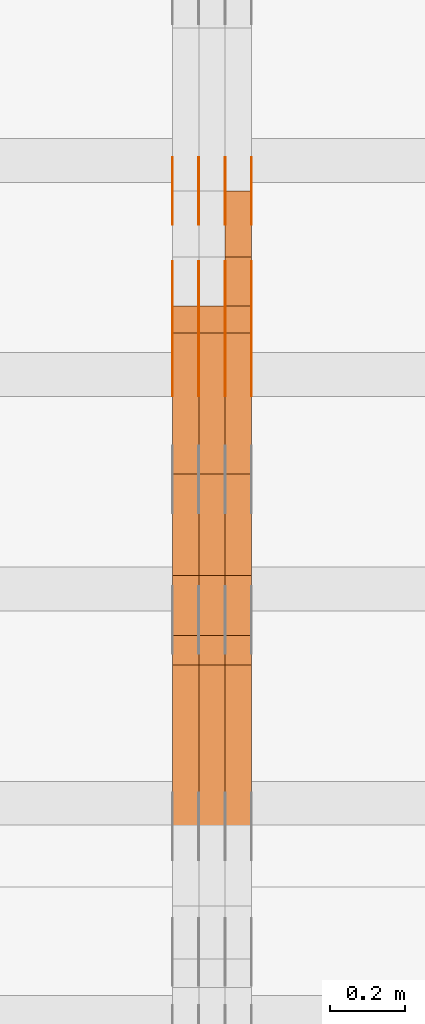
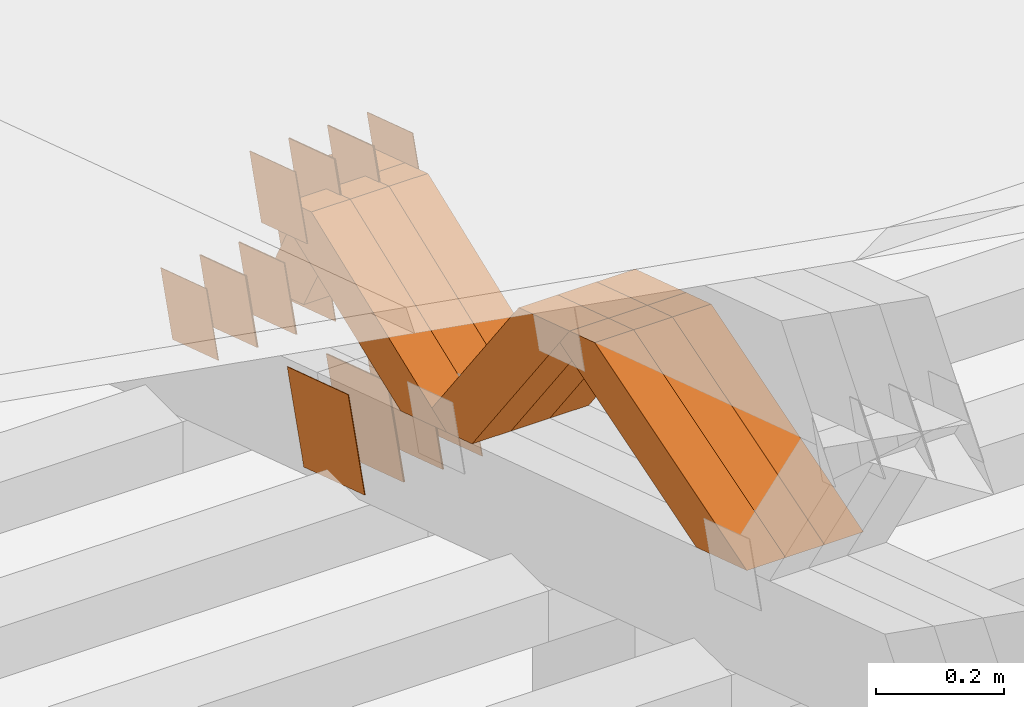
# One storey, part 198 of 385: 28 proxies.
"""IFC2X3 building model written with IfcOpenShell, lengths in millimetres."""

from ifc_helpers import new_model, entity, si_unit, converted_unit, derived_unit, direction, frame, origin, place, context, subcontext, project, spatial, polyline, outline, extrude, source, transform, mapped, material, type_object, type_shapes, element, save


model = new_model("IFC2X3")

# Units and contexts
model_context = context("Model", 3, precision=0.01, world=origin(), true_north=direction((6.12303176911189e-17, 1.0)))
body_context = subcontext(model_context, "Body", "Model", "MODEL_VIEW")
ifc_project = project(units=[si_unit("LENGTHUNIT", "METRE", prefix="MILLI"), si_unit("AREAUNIT", "SQUARE_METRE"), si_unit("VOLUMEUNIT", "CUBIC_METRE"), converted_unit("PLANEANGLEUNIT", "DEGREE", entity("IfcRatioMeasure", 0.0174532925199433), si_unit("PLANEANGLEUNIT", "RADIAN"), dimensions=[0, 0, 0, 0, 0, 0, 0]), si_unit("MASSUNIT", "GRAM", prefix="KILO"), derived_unit("MASSDENSITYUNIT", [(si_unit("MASSUNIT", "GRAM", prefix="KILO"), 1), (si_unit("LENGTHUNIT", "METRE"), -3)]), si_unit("TIMEUNIT", "SECOND"), si_unit("FREQUENCYUNIT", "HERTZ"), si_unit("THERMODYNAMICTEMPERATUREUNIT", "DEGREE_CELSIUS"), derived_unit("THERMALTRANSMITTANCEUNIT", [(si_unit("MASSUNIT", "GRAM", prefix="KILO"), 1), (si_unit("THERMODYNAMICTEMPERATUREUNIT", "KELVIN"), -1), (si_unit("TIMEUNIT", "SECOND"), -3)]), derived_unit("VOLUMETRICFLOWRATEUNIT", [(si_unit("LENGTHUNIT", "METRE"), 3), (si_unit("TIMEUNIT", "SECOND"), -1)]), si_unit("ELECTRICCURRENTUNIT", "AMPERE"), si_unit("ELECTRICVOLTAGEUNIT", "VOLT"), si_unit("POWERUNIT", "WATT"), si_unit("FORCEUNIT", "NEWTON", prefix="KILO"), si_unit("ILLUMINANCEUNIT", "LUX"), si_unit("LUMINOUSFLUXUNIT", "LUMEN"), si_unit("LUMINOUSINTENSITYUNIT", "CANDELA"), derived_unit("USERDEFINED", [(si_unit("MASSUNIT", "GRAM", prefix="KILO"), -1), (si_unit("LENGTHUNIT", "METRE"), -2), (si_unit("TIMEUNIT", "SECOND"), 3), (si_unit("LUMINOUSFLUXUNIT", "LUMEN"), 1)]), derived_unit("LINEARVELOCITYUNIT", [(si_unit("LENGTHUNIT", "METRE"), 1), (si_unit("TIMEUNIT", "SECOND"), -1)]), si_unit("PRESSUREUNIT", "PASCAL"), derived_unit("USERDEFINED", [(si_unit("LENGTHUNIT", "METRE"), -2), (si_unit("MASSUNIT", "GRAM", prefix="KILO"), 1), (si_unit("TIMEUNIT", "SECOND"), -2)])], contexts=[model_context])

# Site, building, storey
site_placement = place(None, origin())
site = spatial("IfcSite", under=ifc_project, at=site_placement, CompositionType="ELEMENT")
building_placement = place(site_placement, origin())
building = spatial("IfcBuilding", under=site, at=building_placement, CompositionType="ELEMENT")
storey_placement = place(building_placement, origin())
storey = spatial("IfcBuildingStorey", under=building, at=storey_placement, Name="Default", CompositionType="ELEMENT", Elevation=0.0)

# Proxies
ifc_material_1 = material(Name="IfcSurfaceStyle #171972")
building_element_proxy_type_1 = type_object("IfcBuildingElementProxyType", PredefinedType="NOTDEFINED", material=ifc_material_1)
shared_shape_1 = source(origin(), body_context, "Body", "SweptSolid", [
    extrude(outline(polyline([(-74.9998794200123, -59.999984515643), (74.9998565677174, -59.999984515643), (74.9998794200123, 59.999984515643), (-74.9998565677174, 59.999984515643), (-74.9998794200123, -59.999984515643)])), frame((75.0000769557496, 60.0000596852268, 0.0), z_axis=(0.0, 0.0, 1.0), x_axis=(-1.0, 0.0, 0.0)), (0.0, 0.0, 1.0), 1.3),
])
type_shapes(building_element_proxy_type_1, [shared_shape_1])
proxy_1_placement = place(building_placement, frame((12386.3, 22649.3668870864, 1282.62115477841), z_axis=(-1.0, 0.0, 0.0), x_axis=(0.0, -0.951056516295124, 0.309016994375039)))
element("IfcBuildingElementProxy", 1, at=proxy_1_placement, inside=storey, type_object=building_element_proxy_type_1, material=ifc_material_1, context=body_context, shape_type="MappedRepresentation", body=[
    mapped(shared_shape_1, transform((0.0, 0.0, 0.0), scale=1.0)),
])
ifc_material_2 = material(Name="IfcSurfaceStyle #171915")
building_element_proxy_type_2 = type_object("IfcBuildingElementProxyType", PredefinedType="NOTDEFINED", material=ifc_material_2)
shared_shape_2 = source(origin(), body_context, "Body", "SweptSolid", [
    extrude(outline(polyline([(-74.9998794200123, -59.999984515643), (74.9998565677174, -59.999984515643), (74.9998794200123, 59.999984515643), (-74.9998565677174, 59.999984515643), (-74.9998794200123, -59.999984515643)])), frame((75.0000769557496, 60.0000596852268, 0.0), z_axis=(0.0, 0.0, 1.0), x_axis=(-1.0, 0.0, 0.0)), (0.0, 0.0, 1.0), 1.3),
])
type_shapes(building_element_proxy_type_2, [shared_shape_2])
proxy_2_placement = place(building_placement, frame((12315.0, 22649.3668870864, 1282.62115477841), z_axis=(-1.0, 0.0, 0.0), x_axis=(0.0, -0.951056516295124, 0.309016994375039)))
element("IfcBuildingElementProxy", 2, at=proxy_2_placement, inside=storey, type_object=building_element_proxy_type_2, material=ifc_material_2, context=body_context, shape_type="MappedRepresentation", body=[
    mapped(shared_shape_2, transform((0.0, 0.0, 0.0), scale=1.0)),
])
ifc_material_3 = material(Name="IfcSurfaceStyle #171858")
building_element_proxy_type_3 = type_object("IfcBuildingElementProxyType", PredefinedType="NOTDEFINED", material=ifc_material_3)
shared_shape_3 = source(origin(), body_context, "Body", "SweptSolid", [
    extrude(outline(polyline([(-74.9998794200123, -59.999984515643), (74.9998565677174, -59.999984515643), (74.9998794200123, 59.999984515643), (-74.9998565677174, 59.999984515643), (-74.9998794200123, -59.999984515643)])), frame((75.0000769557496, 60.0000596852268, 0.0), z_axis=(0.0, 0.0, 1.0), x_axis=(-1.0, 0.0, 0.0)), (0.0, 0.0, 1.0), 1.3),
])
type_shapes(building_element_proxy_type_3, [shared_shape_3])
proxy_3_placement = place(building_placement, frame((12316.3, 22649.3668870864, 1282.62115477841), z_axis=(-1.0, 0.0, 0.0), x_axis=(0.0, -0.951056516295124, 0.309016994375039)))
element("IfcBuildingElementProxy", 3, at=proxy_3_placement, inside=storey, type_object=building_element_proxy_type_3, material=ifc_material_3, context=body_context, shape_type="MappedRepresentation", body=[
    mapped(shared_shape_3, transform((0.0, 0.0, 0.0), scale=1.0)),
])
ifc_material_4 = material(Name="IfcSurfaceStyle #171801")
building_element_proxy_type_4 = type_object("IfcBuildingElementProxyType", PredefinedType="NOTDEFINED", material=ifc_material_4)
shared_shape_4 = source(origin(), body_context, "Body", "SweptSolid", [
    extrude(outline(polyline([(-74.9998794200123, -59.999984515643), (74.9998565677174, -59.999984515643), (74.9998794200123, 59.999984515643), (-74.9998565677174, 59.999984515643), (-74.9998794200123, -59.999984515643)])), frame((75.0000769557496, 60.0000596852268, 0.0), z_axis=(0.0, 0.0, 1.0), x_axis=(-1.0, 0.0, 0.0)), (0.0, 0.0, 1.0), 1.29999999999999),
])
type_shapes(building_element_proxy_type_4, [shared_shape_4])
proxy_4_placement = place(building_placement, frame((12245.0, 22649.3668870864, 1282.62115477841), z_axis=(-1.0, 0.0, 0.0), x_axis=(0.0, -0.951056516295124, 0.309016994375039)))
element("IfcBuildingElementProxy", 4, at=proxy_4_placement, inside=storey, type_object=building_element_proxy_type_4, material=ifc_material_4, context=body_context, shape_type="MappedRepresentation", body=[
    mapped(shared_shape_4, transform((0.0, 0.0, 0.0), scale=1.0)),
])
ifc_material_5 = material(Name="IfcSurfaceStyle #171744")
building_element_proxy_type_5 = type_object("IfcBuildingElementProxyType", PredefinedType="NOTDEFINED", material=ifc_material_5)
shared_shape_5 = source(origin(), body_context, "Body", "SweptSolid", [
    extrude(outline(polyline([(-74.9998794200123, -59.999984515643), (74.9998565677174, -59.999984515643), (74.9998794200123, 59.999984515643), (-74.9998565677174, 59.999984515643), (-74.9998794200123, -59.999984515643)])), frame((75.0000769557496, 60.0000596852268, 0.0), z_axis=(0.0, 0.0, 1.0), x_axis=(-1.0, 0.0, 0.0)), (0.0, 0.0, 1.0), 1.29999999999999),
])
type_shapes(building_element_proxy_type_5, [shared_shape_5])
proxy_5_placement = place(building_placement, frame((12246.3, 22649.3668870864, 1282.62115477841), z_axis=(-1.0, 0.0, 0.0), x_axis=(0.0, -0.951056516295124, 0.309016994375039)))
element("IfcBuildingElementProxy", 5, at=proxy_5_placement, inside=storey, type_object=building_element_proxy_type_5, material=ifc_material_5, context=body_context, shape_type="MappedRepresentation", body=[
    mapped(shared_shape_5, transform((0.0, 0.0, 0.0), scale=1.0)),
])
ifc_material_6 = material(Name="IfcSurfaceStyle #171687")
building_element_proxy_type_6 = type_object("IfcBuildingElementProxyType", PredefinedType="NOTDEFINED", material=ifc_material_6)
shared_shape_6 = source(origin(), body_context, "Body", "SweptSolid", [
    extrude(outline(polyline([(-74.9998794200123, -59.999984515643), (74.9998565677174, -59.999984515643), (74.9998794200123, 59.999984515643), (-74.9998565677174, 59.999984515643), (-74.9998794200123, -59.999984515643)])), frame((75.0000769557496, 60.0000596852268, 0.0), z_axis=(0.0, 0.0, 1.0), x_axis=(-1.0, 0.0, 0.0)), (0.0, 0.0, 1.0), 1.29999999999999),
])
type_shapes(building_element_proxy_type_6, [shared_shape_6])
proxy_6_placement = place(building_placement, frame((12175.0, 22649.3668870864, 1282.62115477841), z_axis=(-1.0, 0.0, 0.0), x_axis=(0.0, -0.951056516295124, 0.309016994375039)))
element("IfcBuildingElementProxy", 6, at=proxy_6_placement, inside=storey, type_object=building_element_proxy_type_6, material=ifc_material_6, context=body_context, shape_type="MappedRepresentation", body=[
    mapped(shared_shape_6, transform((0.0, 0.0, 0.0), scale=1.0)),
])
ifc_material_7 = material(Name="IfcSurfaceStyle #171288")
building_element_proxy_type_7 = type_object("IfcBuildingElementProxyType", PredefinedType="NOTDEFINED", material=ifc_material_7)
shared_shape_7 = source(origin(), body_context, "Body", "SweptSolid", [
    extrude(outline(polyline([(-99.9999579276585, -84.0000593595837), (100.000141865112, -84.0000593595837), (99.9999579276589, 84.0000593595837), (-100.000141865112, 84.0000593595837), (-99.9999579276585, -84.0000593595837)])), frame((100.000141865112, 84.0000593595837, 0.0), z_axis=(0.0, 0.0, 1.0), x_axis=(-1.0, 0.0, 0.0)), (0.0, 0.0, 1.0), 1.3),
])
type_shapes(building_element_proxy_type_7, [shared_shape_7])
proxy_7_placement = place(building_placement, frame((12386.3, 22239.7296395088, 1287.96775368191), z_axis=(-1.0, 0.0, 0.0), x_axis=(0.0, -0.951056516295124, 0.309016994375039)))
element("IfcBuildingElementProxy", 7, at=proxy_7_placement, inside=storey, type_object=building_element_proxy_type_7, material=ifc_material_7, context=body_context, shape_type="MappedRepresentation", body=[
    mapped(shared_shape_7, transform((0.0, 0.0, 0.0), scale=1.0)),
])
ifc_material_8 = material(Name="IfcSurfaceStyle #171231")
building_element_proxy_type_8 = type_object("IfcBuildingElementProxyType", PredefinedType="NOTDEFINED", material=ifc_material_8)
shared_shape_8 = source(origin(), body_context, "Body", "SweptSolid", [
    extrude(outline(polyline([(-99.9999579276585, -84.0000593595837), (100.000141865112, -84.0000593595837), (99.9999579276589, 84.0000593595837), (-100.000141865112, 84.0000593595837), (-99.9999579276585, -84.0000593595837)])), frame((100.000141865112, 84.0000593595837, 0.0), z_axis=(0.0, 0.0, 1.0), x_axis=(-1.0, 0.0, 0.0)), (0.0, 0.0, 1.0), 1.3),
])
type_shapes(building_element_proxy_type_8, [shared_shape_8])
proxy_8_placement = place(building_placement, frame((12315.0, 22239.7296395088, 1287.96775368191), z_axis=(-1.0, 0.0, 0.0), x_axis=(0.0, -0.951056516295124, 0.309016994375039)))
element("IfcBuildingElementProxy", 8, at=proxy_8_placement, inside=storey, type_object=building_element_proxy_type_8, material=ifc_material_8, context=body_context, shape_type="MappedRepresentation", body=[
    mapped(shared_shape_8, transform((0.0, 0.0, 0.0), scale=1.0)),
])
ifc_material_9 = material(Name="IfcSurfaceStyle #171174")
building_element_proxy_type_9 = type_object("IfcBuildingElementProxyType", PredefinedType="NOTDEFINED", material=ifc_material_9)
shared_shape_9 = source(origin(), body_context, "Body", "SweptSolid", [
    extrude(outline(polyline([(-99.9999579276585, -84.0000593595837), (100.000141865112, -84.0000593595837), (99.9999579276589, 84.0000593595837), (-100.000141865112, 84.0000593595837), (-99.9999579276585, -84.0000593595837)])), frame((100.000141865112, 84.0000593595837, 0.0), z_axis=(0.0, 0.0, 1.0), x_axis=(-1.0, 0.0, 0.0)), (0.0, 0.0, 1.0), 1.3),
])
type_shapes(building_element_proxy_type_9, [shared_shape_9])
proxy_9_placement = place(building_placement, frame((12316.3, 22239.7296395088, 1287.96775368191), z_axis=(-1.0, 0.0, 0.0), x_axis=(0.0, -0.951056516295124, 0.309016994375039)))
element("IfcBuildingElementProxy", 9, at=proxy_9_placement, inside=storey, type_object=building_element_proxy_type_9, material=ifc_material_9, context=body_context, shape_type="MappedRepresentation", body=[
    mapped(shared_shape_9, transform((0.0, 0.0, 0.0), scale=1.0)),
])
ifc_material_10 = material(Name="IfcSurfaceStyle #171117")
building_element_proxy_type_10 = type_object("IfcBuildingElementProxyType", PredefinedType="NOTDEFINED", material=ifc_material_10)
shared_shape_10 = source(origin(), body_context, "Body", "SweptSolid", [
    extrude(outline(polyline([(-99.9999579276585, -84.0000593595837), (100.000141865112, -84.0000593595837), (99.9999579276589, 84.0000593595837), (-100.000141865112, 84.0000593595837), (-99.9999579276585, -84.0000593595837)])), frame((100.000141865112, 84.0000593595837, 0.0), z_axis=(0.0, 0.0, 1.0), x_axis=(-1.0, 0.0, 0.0)), (0.0, 0.0, 1.0), 1.29999999999998),
])
type_shapes(building_element_proxy_type_10, [shared_shape_10])
proxy_10_placement = place(building_placement, frame((12245.0, 22239.7296395088, 1287.96775368191), z_axis=(-1.0, 0.0, 0.0), x_axis=(0.0, -0.951056516295124, 0.309016994375039)))
element("IfcBuildingElementProxy", 10, at=proxy_10_placement, inside=storey, type_object=building_element_proxy_type_10, material=ifc_material_10, context=body_context, shape_type="MappedRepresentation", body=[
    mapped(shared_shape_10, transform((0.0, 0.0, 0.0), scale=1.0)),
])
ifc_material_11 = material(Name="IfcSurfaceStyle #171060")
building_element_proxy_type_11 = type_object("IfcBuildingElementProxyType", PredefinedType="NOTDEFINED", material=ifc_material_11)
shared_shape_11 = source(origin(), body_context, "Body", "SweptSolid", [
    extrude(outline(polyline([(-99.9999579276585, -84.0000593595837), (100.000141865112, -84.0000593595837), (99.9999579276589, 84.0000593595837), (-100.000141865112, 84.0000593595837), (-99.9999579276585, -84.0000593595837)])), frame((100.000141865112, 84.0000593595837, 0.0), z_axis=(0.0, 0.0, 1.0), x_axis=(-1.0, 0.0, 0.0)), (0.0, 0.0, 1.0), 1.29999999999998),
])
type_shapes(building_element_proxy_type_11, [shared_shape_11])
proxy_11_placement = place(building_placement, frame((12246.3, 22239.7296395088, 1287.96775368191), z_axis=(-1.0, 0.0, 0.0), x_axis=(0.0, -0.951056516295124, 0.309016994375039)))
element("IfcBuildingElementProxy", 11, at=proxy_11_placement, inside=storey, type_object=building_element_proxy_type_11, material=ifc_material_11, context=body_context, shape_type="MappedRepresentation", body=[
    mapped(shared_shape_11, transform((0.0, 0.0, 0.0), scale=1.0)),
])
ifc_material_12 = material(Name="IfcSurfaceStyle #171003")
building_element_proxy_type_12 = type_object("IfcBuildingElementProxyType", PredefinedType="NOTDEFINED", material=ifc_material_12)
shared_shape_12 = source(origin(), body_context, "Body", "SweptSolid", [
    extrude(outline(polyline([(-99.9999579276585, -84.0000593595837), (100.000141865112, -84.0000593595837), (99.9999579276589, 84.0000593595837), (-100.000141865112, 84.0000593595837), (-99.9999579276585, -84.0000593595837)])), frame((100.000141865112, 84.0000593595837, 0.0), z_axis=(0.0, 0.0, 1.0), x_axis=(-1.0, 0.0, 0.0)), (0.0, 0.0, 1.0), 1.29999999999999),
])
type_shapes(building_element_proxy_type_12, [shared_shape_12])
proxy_12_placement = place(building_placement, frame((12175.0, 22239.7296395088, 1287.96775368191), z_axis=(-1.0, 0.0, 0.0), x_axis=(0.0, -0.951056516295124, 0.309016994375039)))
element("IfcBuildingElementProxy", 12, at=proxy_12_placement, inside=storey, type_object=building_element_proxy_type_12, material=ifc_material_12, context=body_context, shape_type="MappedRepresentation", body=[
    mapped(shared_shape_12, transform((0.0, 0.0, 0.0), scale=1.0)),
])
ifc_material_13 = material(Name="IfcSurfaceStyle #162738")
building_element_proxy_type_13 = type_object("IfcBuildingElementProxyType", PredefinedType="NOTDEFINED", material=ifc_material_13)
shared_shape_13 = source(origin(), body_context, "Body", "SweptSolid", [
    extrude(outline(polyline([(-74.9998794200069, -59.9999845156358), (74.9998565677229, -59.9999845156358), (74.9998794200069, 59.9999845156358), (-74.9998565677229, 59.9999845156358), (-74.9998794200069, -59.9999845156358)])), frame((75.0000966453795, 60.0000596852335, 0.0), z_axis=(0.0, 0.0, 1.0), x_axis=(-1.0, 0.0, 0.0)), (0.0, 0.0, 1.0), 1.3),
])
type_shapes(building_element_proxy_type_13, [shared_shape_13])
proxy_13_placement = place(building_placement, frame((12386.3, 22372.1881948749, 1673.08440552992), z_axis=(-1.0, 0.0, 0.0), x_axis=(0.0, -0.951056516295154, 0.309016994374948)))
element("IfcBuildingElementProxy", 13, at=proxy_13_placement, inside=storey, type_object=building_element_proxy_type_13, material=ifc_material_13, context=body_context, shape_type="MappedRepresentation", body=[
    mapped(shared_shape_13, transform((0.0, 0.0, 0.0), scale=1.0)),
])
ifc_material_14 = material(Name="IfcSurfaceStyle #162681")
building_element_proxy_type_14 = type_object("IfcBuildingElementProxyType", PredefinedType="NOTDEFINED", material=ifc_material_14)
shared_shape_14 = source(origin(), body_context, "Body", "SweptSolid", [
    extrude(outline(polyline([(-74.9998794200069, -59.9999845156358), (74.9998565677229, -59.9999845156358), (74.9998794200069, 59.9999845156358), (-74.9998565677229, 59.9999845156358), (-74.9998794200069, -59.9999845156358)])), frame((75.0000966453795, 60.0000596852335, 0.0), z_axis=(0.0, 0.0, 1.0), x_axis=(-1.0, 0.0, 0.0)), (0.0, 0.0, 1.0), 1.3),
])
type_shapes(building_element_proxy_type_14, [shared_shape_14])
proxy_14_placement = place(building_placement, frame((12315.0, 22372.1881948749, 1673.08440552992), z_axis=(-1.0, 0.0, 0.0), x_axis=(0.0, -0.951056516295154, 0.309016994374948)))
element("IfcBuildingElementProxy", 14, at=proxy_14_placement, inside=storey, type_object=building_element_proxy_type_14, material=ifc_material_14, context=body_context, shape_type="MappedRepresentation", body=[
    mapped(shared_shape_14, transform((0.0, 0.0, 0.0), scale=1.0)),
])
ifc_material_15 = material(Name="IfcSurfaceStyle #162624")
building_element_proxy_type_15 = type_object("IfcBuildingElementProxyType", PredefinedType="NOTDEFINED", material=ifc_material_15)
shared_shape_15 = source(origin(), body_context, "Body", "SweptSolid", [
    extrude(outline(polyline([(-74.9998794200069, -59.9999845156358), (74.9998565677229, -59.9999845156358), (74.9998794200069, 59.9999845156358), (-74.9998565677229, 59.9999845156358), (-74.9998794200069, -59.9999845156358)])), frame((75.0000966453795, 60.0000596852335, 0.0), z_axis=(0.0, 0.0, 1.0), x_axis=(-1.0, 0.0, 0.0)), (0.0, 0.0, 1.0), 1.3),
])
type_shapes(building_element_proxy_type_15, [shared_shape_15])
proxy_15_placement = place(building_placement, frame((12316.3, 22372.1881948749, 1673.08440552992), z_axis=(-1.0, 0.0, 0.0), x_axis=(0.0, -0.951056516295154, 0.309016994374948)))
element("IfcBuildingElementProxy", 15, at=proxy_15_placement, inside=storey, type_object=building_element_proxy_type_15, material=ifc_material_15, context=body_context, shape_type="MappedRepresentation", body=[
    mapped(shared_shape_15, transform((0.0, 0.0, 0.0), scale=1.0)),
])
ifc_material_16 = material(Name="IfcSurfaceStyle #162567")
building_element_proxy_type_16 = type_object("IfcBuildingElementProxyType", PredefinedType="NOTDEFINED", material=ifc_material_16)
shared_shape_16 = source(origin(), body_context, "Body", "SweptSolid", [
    extrude(outline(polyline([(-74.9998794200069, -59.9999845156358), (74.9998565677229, -59.9999845156358), (74.9998794200069, 59.9999845156358), (-74.9998565677229, 59.9999845156358), (-74.9998794200069, -59.9999845156358)])), frame((75.0000966453795, 60.0000596852335, 0.0), z_axis=(0.0, 0.0, 1.0), x_axis=(-1.0, 0.0, 0.0)), (0.0, 0.0, 1.0), 1.29999999999999),
])
type_shapes(building_element_proxy_type_16, [shared_shape_16])
proxy_16_placement = place(building_placement, frame((12245.0, 22372.1881948749, 1673.08440552992), z_axis=(-1.0, 0.0, 0.0), x_axis=(0.0, -0.951056516295154, 0.309016994374948)))
element("IfcBuildingElementProxy", 16, at=proxy_16_placement, inside=storey, type_object=building_element_proxy_type_16, material=ifc_material_16, context=body_context, shape_type="MappedRepresentation", body=[
    mapped(shared_shape_16, transform((0.0, 0.0, 0.0), scale=1.0)),
])
ifc_material_17 = material(Name="IfcSurfaceStyle #162510")
building_element_proxy_type_17 = type_object("IfcBuildingElementProxyType", PredefinedType="NOTDEFINED", material=ifc_material_17)
shared_shape_17 = source(origin(), body_context, "Body", "SweptSolid", [
    extrude(outline(polyline([(-74.9998794200069, -59.9999845156358), (74.9998565677229, -59.9999845156358), (74.9998794200069, 59.9999845156358), (-74.9998565677229, 59.9999845156358), (-74.9998794200069, -59.9999845156358)])), frame((75.0000966453795, 60.0000596852335, 0.0), z_axis=(0.0, 0.0, 1.0), x_axis=(-1.0, 0.0, 0.0)), (0.0, 0.0, 1.0), 1.29999999999999),
])
type_shapes(building_element_proxy_type_17, [shared_shape_17])
proxy_17_placement = place(building_placement, frame((12246.3, 22372.1881948749, 1673.08440552992), z_axis=(-1.0, 0.0, 0.0), x_axis=(0.0, -0.951056516295154, 0.309016994374948)))
element("IfcBuildingElementProxy", 17, at=proxy_17_placement, inside=storey, type_object=building_element_proxy_type_17, material=ifc_material_17, context=body_context, shape_type="MappedRepresentation", body=[
    mapped(shared_shape_17, transform((0.0, 0.0, 0.0), scale=1.0)),
])
ifc_material_18 = material(Name="IfcSurfaceStyle #162453")
building_element_proxy_type_18 = type_object("IfcBuildingElementProxyType", PredefinedType="NOTDEFINED", material=ifc_material_18)
shared_shape_18 = source(origin(), body_context, "Body", "SweptSolid", [
    extrude(outline(polyline([(-74.9998794200069, -59.9999845156358), (74.9998565677229, -59.9999845156358), (74.9998794200069, 59.9999845156358), (-74.9998565677229, 59.9999845156358), (-74.9998794200069, -59.9999845156358)])), frame((75.0000966453795, 60.0000596852335, 0.0), z_axis=(0.0, 0.0, 1.0), x_axis=(-1.0, 0.0, 0.0)), (0.0, 0.0, 1.0), 1.29999999999999),
])
type_shapes(building_element_proxy_type_18, [shared_shape_18])
proxy_18_placement = place(building_placement, frame((12175.0, 22372.1881948749, 1673.08440552992), z_axis=(-1.0, 0.0, 0.0), x_axis=(0.0, -0.951056516295154, 0.309016994374948)))
element("IfcBuildingElementProxy", 18, at=proxy_18_placement, inside=storey, type_object=building_element_proxy_type_18, material=ifc_material_18, context=body_context, shape_type="MappedRepresentation", body=[
    mapped(shared_shape_18, transform((0.0, 0.0, 0.0), scale=1.0)),
])
ifc_material_19 = material(Name="IfcSurfaceStyle #151182")
building_element_proxy_type_19 = type_object("IfcBuildingElementProxyType", Name="T1-W20 151180", PredefinedType="NOTDEFINED", material=ifc_material_19)
shared_shape_19 = source(origin(), body_context, "Body", "SweptSolid", [
    extrude(outline(polyline([(-355.264945969921, -47.5000317999193), (141.064821099313, -47.5000317999193), (208.541978467889, 8.19311626391928e-05), (225.96877763549, 47.499990834338), (-220.31063123277, 47.4999908343379), (-355.264945969921, -47.5000317999193)])), frame((225.968921063481, 47.5000683592689, 0.0), z_axis=(0.0, 0.0, 1.0), x_axis=(-1.0, 0.0, 0.0)), (0.0, 0.0, 1.0), 70.0),
])
type_shapes(building_element_proxy_type_19, [shared_shape_19])
proxy_19_placement = place(building_placement, frame((12385.0, 21443.7472302196, 2007.54830804072), z_axis=(-1.0, 0.0, 0.0), x_axis=(0.0, -0.95556995517236, -0.29476441571515)))
element("IfcBuildingElementProxy", 19, at=proxy_19_placement, inside=storey, type_object=building_element_proxy_type_19, material=ifc_material_19, Name="T1-W20", context=body_context, shape_type="MappedRepresentation", body=[
    mapped(shared_shape_19, transform((0.0, 0.0, 0.0), scale=1.0)),
])
ifc_material_20 = material(Name="IfcSurfaceStyle #151116")
building_element_proxy_type_20 = type_object("IfcBuildingElementProxyType", Name="T1-W20 151114", PredefinedType="NOTDEFINED", material=ifc_material_20)
shared_shape_20 = source(origin(), body_context, "Body", "SweptSolid", [
    extrude(outline(polyline([(-355.264945969921, -47.5000317999193), (141.064821099313, -47.5000317999193), (208.541978467889, 8.19311626391928e-05), (225.96877763549, 47.499990834338), (-220.31063123277, 47.4999908343379), (-355.264945969921, -47.5000317999193)])), frame((225.968921063481, 47.5000683592689, 0.0), z_axis=(0.0, 0.0, 1.0), x_axis=(-1.0, 0.0, 0.0)), (0.0, 0.0, 1.0), 70.0),
])
type_shapes(building_element_proxy_type_20, [shared_shape_20])
proxy_20_placement = place(building_placement, frame((12315.0, 21443.7472302196, 2007.54830804072), z_axis=(-1.0, 0.0, 0.0), x_axis=(0.0, -0.95556995517236, -0.29476441571515)))
element("IfcBuildingElementProxy", 20, at=proxy_20_placement, inside=storey, type_object=building_element_proxy_type_20, material=ifc_material_20, Name="T1-W20", context=body_context, shape_type="MappedRepresentation", body=[
    mapped(shared_shape_20, transform((0.0, 0.0, 0.0), scale=1.0)),
])
ifc_material_21 = material(Name="IfcSurfaceStyle #151050")
building_element_proxy_type_21 = type_object("IfcBuildingElementProxyType", Name="T1-W20 151048", PredefinedType="NOTDEFINED", material=ifc_material_21)
shared_shape_21 = source(origin(), body_context, "Body", "SweptSolid", [
    extrude(outline(polyline([(-355.264945969921, -47.5000317999193), (141.064821099313, -47.5000317999193), (208.541978467889, 8.19311626391928e-05), (225.96877763549, 47.499990834338), (-220.31063123277, 47.4999908343379), (-355.264945969921, -47.5000317999193)])), frame((225.968921063481, 47.5000683592689, 0.0), z_axis=(0.0, 0.0, 1.0), x_axis=(-1.0, 0.0, 0.0)), (0.0, 0.0, 1.0), 70.0),
])
type_shapes(building_element_proxy_type_21, [shared_shape_21])
proxy_21_placement = place(building_placement, frame((12245.0, 21443.7472302196, 2007.54830804072), z_axis=(-1.0, 0.0, 0.0), x_axis=(0.0, -0.95556995517236, -0.29476441571515)))
element("IfcBuildingElementProxy", 21, at=proxy_21_placement, inside=storey, type_object=building_element_proxy_type_21, material=ifc_material_21, Name="T1-W20", context=body_context, shape_type="MappedRepresentation", body=[
    mapped(shared_shape_21, transform((0.0, 0.0, 0.0), scale=1.0)),
])
ifc_material_22 = material(Name="IfcSurfaceStyle #150786")
building_element_proxy_type_22 = type_object("IfcBuildingElementProxyType", Name="T1-W18 150784", PredefinedType="NOTDEFINED", material=ifc_material_22)
shared_shape_22 = source(origin(), body_context, "Body", "SweptSolid", [
    extrude(outline(polyline([(-221.504996322134, -47.4999929258616), (225.406467948779, -47.4999929258616), (211.663832468686, -0.000107703153482008), (143.08905281687, 47.5000467774384), (-358.6543569122, 47.5000467774384), (-221.504996322134, -47.4999929258616)])), frame((225.406576158364, 47.5000467774384, 0.0), z_axis=(0.0, 0.0, 1.0), x_axis=(-1.0, 0.0, 0.0)), (0.0, 0.0, 1.0), 70.0),
])
type_shapes(building_element_proxy_type_22, [shared_shape_22])
proxy_22_placement = place(building_placement, frame((12385.0, 21766.9513837803, 1583.13813361817), z_axis=(-1.0, 0.0, 0.0), x_axis=(0.0, -0.605858491298265, 0.795572428206126)))
element("IfcBuildingElementProxy", 22, at=proxy_22_placement, inside=storey, type_object=building_element_proxy_type_22, material=ifc_material_22, Name="T1-W18", context=body_context, shape_type="MappedRepresentation", body=[
    mapped(shared_shape_22, transform((0.0, 0.0, 0.0), scale=1.0)),
])
ifc_material_23 = material(Name="IfcSurfaceStyle #150720")
building_element_proxy_type_23 = type_object("IfcBuildingElementProxyType", Name="T1-W18 150718", PredefinedType="NOTDEFINED", material=ifc_material_23)
shared_shape_23 = source(origin(), body_context, "Body", "SweptSolid", [
    extrude(outline(polyline([(-221.504996322134, -47.4999929258616), (225.406467948779, -47.4999929258616), (211.663832468686, -0.000107703153482008), (143.08905281687, 47.5000467774384), (-358.6543569122, 47.5000467774384), (-221.504996322134, -47.4999929258616)])), frame((225.406576158364, 47.5000467774384, 0.0), z_axis=(0.0, 0.0, 1.0), x_axis=(-1.0, 0.0, 0.0)), (0.0, 0.0, 1.0), 70.0),
])
type_shapes(building_element_proxy_type_23, [shared_shape_23])
proxy_23_placement = place(building_placement, frame((12315.0, 21766.9513837803, 1583.13813361817), z_axis=(-1.0, 0.0, 0.0), x_axis=(0.0, -0.605858491298265, 0.795572428206126)))
element("IfcBuildingElementProxy", 23, at=proxy_23_placement, inside=storey, type_object=building_element_proxy_type_23, material=ifc_material_23, Name="T1-W18", context=body_context, shape_type="MappedRepresentation", body=[
    mapped(shared_shape_23, transform((0.0, 0.0, 0.0), scale=1.0)),
])
ifc_material_24 = material(Name="IfcSurfaceStyle #150654")
building_element_proxy_type_24 = type_object("IfcBuildingElementProxyType", Name="T1-W18 150652", PredefinedType="NOTDEFINED", material=ifc_material_24)
shared_shape_24 = source(origin(), body_context, "Body", "SweptSolid", [
    extrude(outline(polyline([(-221.504996322134, -47.4999929258616), (225.406467948779, -47.4999929258616), (211.663832468686, -0.000107703153482008), (143.08905281687, 47.5000467774384), (-358.6543569122, 47.5000467774384), (-221.504996322134, -47.4999929258616)])), frame((225.406576158364, 47.5000467774384, 0.0), z_axis=(0.0, 0.0, 1.0), x_axis=(-1.0, 0.0, 0.0)), (0.0, 0.0, 1.0), 70.0),
])
type_shapes(building_element_proxy_type_24, [shared_shape_24])
proxy_24_placement = place(building_placement, frame((12245.0, 21766.9513837803, 1583.13813361817), z_axis=(-1.0, 0.0, 0.0), x_axis=(0.0, -0.605858491298265, 0.795572428206126)))
element("IfcBuildingElementProxy", 24, at=proxy_24_placement, inside=storey, type_object=building_element_proxy_type_24, material=ifc_material_24, Name="T1-W18", context=body_context, shape_type="MappedRepresentation", body=[
    mapped(shared_shape_24, transform((0.0, 0.0, 0.0), scale=1.0)),
])
ifc_material_25 = material(Name="IfcSurfaceStyle #150390")
building_element_proxy_type_25 = type_object("IfcBuildingElementProxyType", Name="T1-W30 150388", PredefinedType="NOTDEFINED", material=ifc_material_25)
shared_shape_25 = source(origin(), body_context, "Body", "SweptSolid", [
    extrude(outline(polyline([(-319.322304176575, -47.5000259045904), (133.154090927094, -47.5000259045904), (191.489196707701, 6.99403755251016e-06), (197.330697834052, 47.5000224075717), (-202.651681292271, 47.5000224075717), (-319.322304176575, -47.5000259045904)])), frame((197.330834478517, 47.5000608592405, 0.0), z_axis=(0.0, 0.0, 1.0), x_axis=(-1.0, 0.0, 0.0)), (0.0, 0.0, 1.0), 70.0),
])
type_shapes(building_element_proxy_type_25, [shared_shape_25])
proxy_25_placement = place(building_placement, frame((12385.0, 22312.5352975627, 1720.70362673362), z_axis=(-1.0, 0.0, 0.0), x_axis=(0.0, -0.932610696879359, -0.360884036868072)))
element("IfcBuildingElementProxy", 25, at=proxy_25_placement, inside=storey, type_object=building_element_proxy_type_25, material=ifc_material_25, Name="T1-W30", context=body_context, shape_type="MappedRepresentation", body=[
    mapped(shared_shape_25, transform((0.0, 0.0, 0.0), scale=1.0)),
])
ifc_material_26 = material(Name="IfcSurfaceStyle #150324")
building_element_proxy_type_26 = type_object("IfcBuildingElementProxyType", Name="T1-W30 150322", PredefinedType="NOTDEFINED", material=ifc_material_26)
shared_shape_26 = source(origin(), body_context, "Body", "SweptSolid", [
    extrude(outline(polyline([(-319.322304176575, -47.5000259045904), (133.154090927094, -47.5000259045904), (191.489196707701, 6.99403755251016e-06), (197.330697834052, 47.5000224075717), (-202.651681292271, 47.5000224075717), (-319.322304176575, -47.5000259045904)])), frame((197.330834478517, 47.5000608592405, 0.0), z_axis=(0.0, 0.0, 1.0), x_axis=(-1.0, 0.0, 0.0)), (0.0, 0.0, 1.0), 70.0),
])
type_shapes(building_element_proxy_type_26, [shared_shape_26])
proxy_26_placement = place(building_placement, frame((12315.0, 22312.5352975627, 1720.70362673362), z_axis=(-1.0, 0.0, 0.0), x_axis=(0.0, -0.932610696879359, -0.360884036868072)))
element("IfcBuildingElementProxy", 26, at=proxy_26_placement, inside=storey, type_object=building_element_proxy_type_26, material=ifc_material_26, Name="T1-W30", context=body_context, shape_type="MappedRepresentation", body=[
    mapped(shared_shape_26, transform((0.0, 0.0, 0.0), scale=1.0)),
])
ifc_material_27 = material(Name="IfcSurfaceStyle #150258")
building_element_proxy_type_27 = type_object("IfcBuildingElementProxyType", Name="T1-W30 150256", PredefinedType="NOTDEFINED", material=ifc_material_27)
shared_shape_27 = source(origin(), body_context, "Body", "SweptSolid", [
    extrude(outline(polyline([(-319.322304176575, -47.5000259045904), (133.154090927094, -47.5000259045904), (191.489196707701, 6.99403755251016e-06), (197.330697834052, 47.5000224075717), (-202.651681292271, 47.5000224075717), (-319.322304176575, -47.5000259045904)])), frame((197.330834478517, 47.5000608592405, 0.0), z_axis=(0.0, 0.0, 1.0), x_axis=(-1.0, 0.0, 0.0)), (0.0, 0.0, 1.0), 70.0),
])
type_shapes(building_element_proxy_type_27, [shared_shape_27])
proxy_27_placement = place(building_placement, frame((12245.0, 22312.5352975627, 1720.70362673362), z_axis=(-1.0, 0.0, 0.0), x_axis=(0.0, -0.932610696879359, -0.360884036868072)))
element("IfcBuildingElementProxy", 27, at=proxy_27_placement, inside=storey, type_object=building_element_proxy_type_27, material=ifc_material_27, Name="T1-W30", context=body_context, shape_type="MappedRepresentation", body=[
    mapped(shared_shape_27, transform((0.0, 0.0, 0.0), scale=1.0)),
])
ifc_material_28 = material(Name="IfcSurfaceStyle #149994")
building_element_proxy_type_28 = type_object("IfcBuildingElementProxyType", Name="T1-W41 149992", PredefinedType="NOTDEFINED", material=ifc_material_28)
shared_shape_28 = source(origin(), body_context, "Body", "SweptSolid", [
    extrude(outline(polyline([(-190.064783497519, -47.5001011048749), (182.590736871656, -47.5001011048749), (172.978793750747, 0.000111395300689243), (123.505951450908, 47.5000454072246), (-289.010698575792, 47.5000454072246), (-190.064783497519, -47.5001011048749)])), frame((182.590736871656, 47.5001973817447, 0.0), z_axis=(0.0, 0.0, 1.0), x_axis=(-1.0, 0.0, 0.0)), (0.0, 0.0, 1.0), 70.0),
])
type_shapes(building_element_proxy_type_28, [shared_shape_28])
proxy_28_placement = place(building_placement, frame((12385.0, 22512.5506969063, 1347.13648051689), z_axis=(-1.0, 0.0, 0.0), x_axis=(0.0, -0.472020158706979, 0.881587755004706)))
element("IfcBuildingElementProxy", 28, at=proxy_28_placement, inside=storey, type_object=building_element_proxy_type_28, material=ifc_material_28, Name="T1-W41", context=body_context, shape_type="MappedRepresentation", body=[
    mapped(shared_shape_28, transform((0.0, 0.0, 0.0), scale=1.0)),
])

save(model, "model.ifc")
